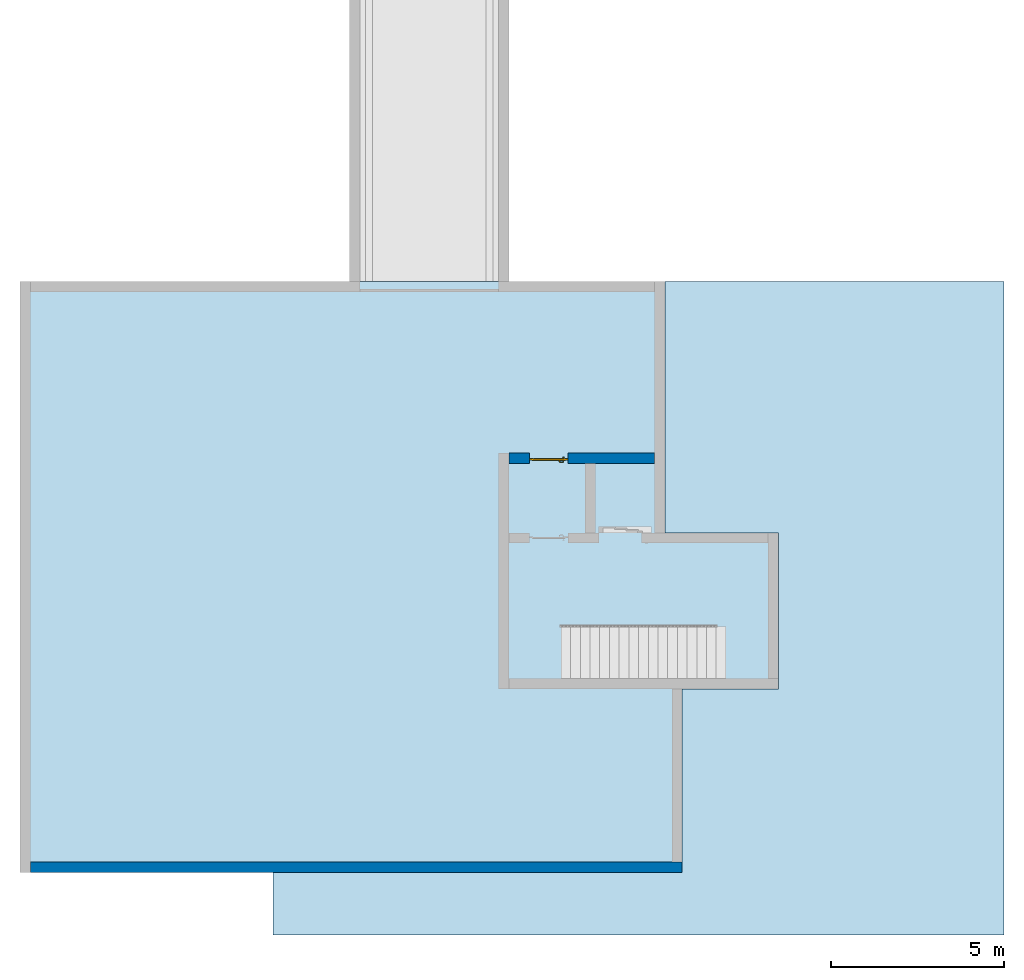
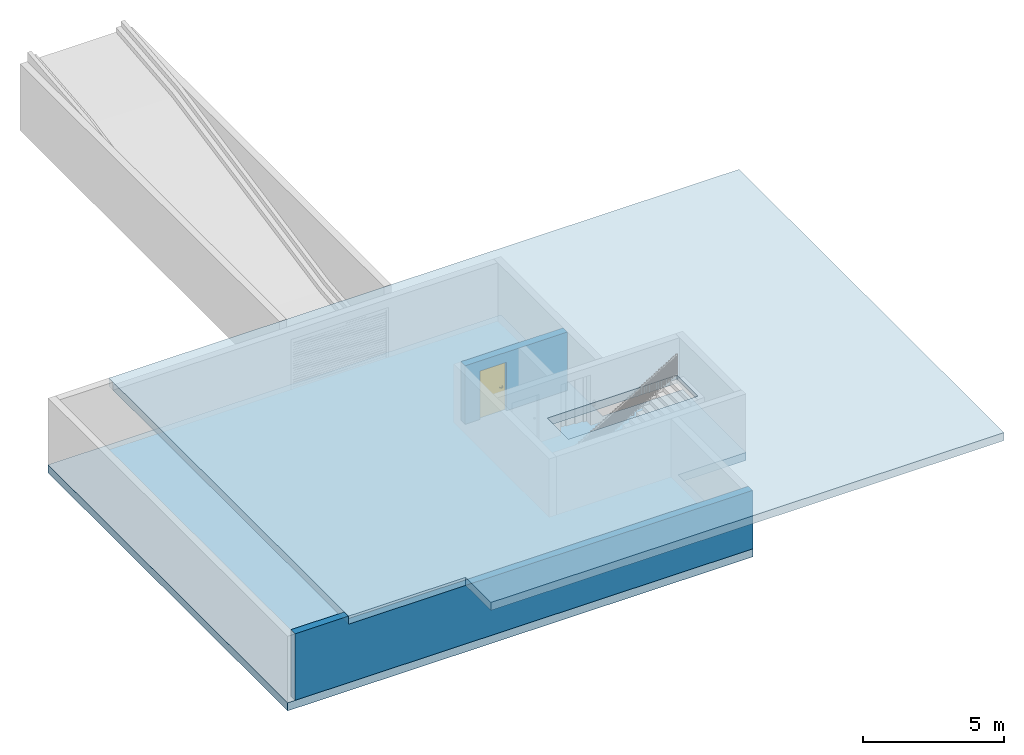
# One storey, part 1 of 6: 2 slabs, 2 walls, 1 door, 1 opening.
"""IFC4 building model written with IfcOpenShell, lengths in metres."""

from ifc_helpers import new_model, entity, si_unit, converted_unit, derived_unit, direction, frame, origin_with_axes, place, context, subcontext, project, spatial, polygons, source, transform, mapped, material, type_object, element, fill, save


model = new_model("IFC4")

# Units and contexts
model_context = context("Model", 3, precision=1e-05, world=origin_with_axes(), true_north=direction((0.0, 1.0)))
body_context = subcontext(model_context, "Body", "Model", "MODEL_VIEW")
ifc_project = project(units=[si_unit("LENGTHUNIT", "METRE"), si_unit("AREAUNIT", "SQUARE_METRE"), si_unit("VOLUMEUNIT", "CUBIC_METRE"), converted_unit("PLANEANGLEUNIT", "DEGREE", entity("IfcPlaneAngleMeasure", 0.0174532925199), si_unit("PLANEANGLEUNIT", "RADIAN"), dimensions=[0, 0, 0, 0, 0, 0, 0]), converted_unit("TIMEUNIT", "Year", entity("IfcTimeMeasure", 31556926.0), si_unit("TIMEUNIT", "SECOND"), dimensions=[0, 0, 1, 0, 0, 0, 0]), si_unit("MASSUNIT", "GRAM", prefix="KILO"), si_unit("THERMODYNAMICTEMPERATUREUNIT", "DEGREE_CELSIUS"), si_unit("LUMINOUSINTENSITYUNIT", "LUMEN"), si_unit("ENERGYUNIT", "JOULE", prefix="MEGA"), derived_unit("THERMALCONDUCTANCEUNIT", [(si_unit("POWERUNIT", "WATT"), 1), (si_unit("LENGTHUNIT", "METRE"), -1), (si_unit("THERMODYNAMICTEMPERATUREUNIT", "KELVIN"), -1)]), derived_unit("SPECIFICHEATCAPACITYUNIT", [(si_unit("ENERGYUNIT", "JOULE"), 1), (si_unit("MASSUNIT", "GRAM", prefix="KILO"), -1), (si_unit("THERMODYNAMICTEMPERATUREUNIT", "KELVIN"), -1)]), derived_unit("MASSDENSITYUNIT", [(si_unit("MASSUNIT", "GRAM", prefix="KILO"), 1), (si_unit("VOLUMEUNIT", "CUBIC_METRE"), -1)])], contexts=[model_context])

# Site, building, storey, space
site_placement = place(None, origin_with_axes())
site = spatial("IfcSite", under=ifc_project, at=site_placement, CompositionType="ELEMENT")
building_placement = place(site_placement, origin_with_axes())
building = spatial("IfcBuilding", under=site, at=building_placement, CompositionType="ELEMENT")
storey_placement = place(building_placement, frame((0.0, 0.0, -2.89), z_axis=(0.0, 0.0, 1.0), x_axis=(1.0, 0.0, 0.0)))
storey = spatial("IfcBuildingStorey", under=building, at=storey_placement, Name="-1. Geschoss", CompositionType="ELEMENT", Elevation=-2.89)
space_placement = place(storey_placement, frame((-13.7421993804, 7.17118776896, 0.0), z_axis=(0.0, 0.0, 1.0), x_axis=(-1.0, 0.0, 0.0)))
space = spatial("IfcSpace", under=storey, at=space_placement, CompositionType="ELEMENT", PredefinedType="INTERNAL")

# Slabs
ifc_material = material()
slab_type = type_object("IfcSlabType", Name="350", PredefinedType="NOTDEFINED")
slab_1_placement = place(space_placement, frame((-2.0, -1.75, 2.89), z_axis=(0.0, 0.0, 1.0), x_axis=(-1.0, 0.0, 0.0)))
element("IfcSlab", 1, at=slab_1_placement, inside=space, type_object=slab_type, material=ifc_material, Name="Decke-001", PredefinedType="NOTDEFINED", context=body_context, shape_type="Tessellation", body=[
    polygons([(-4.8, -17.05, 0.0), (-4.8, 0.0, 0.0), (-4.8, 0.0, -0.35), (-4.8, -17.05, -0.35), (21.08, -18.85, 0.0), (21.08, 0.0, 0.0), (0.0, -17.05, 0.0), (0.0, -18.85, 0.0), (12.78, -11.45, 0.0), (7.46, -11.45, 0.0), (7.46, -9.95, 0.0), (12.78, -9.95, 0.0), (21.08, 0.0, -0.35), (21.08, -18.85, -0.35), (0.0, -18.85, -0.35), (0.0, -17.05, -0.35), (12.78, -11.45, -0.35), (12.78, -9.95, -0.35), (7.46, -9.95, -0.35), (7.46, -11.45, -0.35)], [[[1, 2, 3, 4]], [[5, 6, 2, 1, 7, 8], [9, 10, 11, 12]], [[2, 6, 13, 3]], [[4, 3, 13, 14, 15, 16], [17, 18, 19, 20]], [[7, 1, 4, 16]], [[6, 5, 14, 13]], [[8, 7, 16, 15]], [[5, 8, 15, 14]], [[10, 9, 17, 20]], [[11, 10, 20, 19]], [[12, 11, 19, 18]], [[9, 12, 18, 17]]], closed=True),
])
slab_2_placement = place(storey_placement, frame((-19.0421993804, 8.92118776896, 0.0), z_axis=(0.0, 0.0, 1.0), x_axis=(1.0, 0.0, 0.0)))
element("IfcSlab", 2, at=slab_2_placement, inside=storey, type_object=slab_type, material=ifc_material, Name="Decke-001", PredefinedType="NOTDEFINED", context=body_context, shape_type="Tessellation", body=[
    polygons([(0.0, 0.0, 0.0), (0.0, 0.0, -0.35), (0.0, -17.05, -0.35), (0.0, -17.05, 0.0), (18.6, 0.0, 0.0), (18.6, 0.0, -0.35), (18.6, -7.25, -0.35), (21.88, -7.25, -0.35), (21.88, -11.75, -0.35), (19.1, -11.75, -0.35), (19.1, -17.05, -0.35), (19.1, -17.05, 0.0), (19.1, -11.75, 0.0), (21.88, -11.75, 0.0), (21.88, -7.25, 0.0), (18.6, -7.25, 0.0)], [[[1, 2, 3, 4]], [[5, 6, 2, 1]], [[3, 2, 6, 7, 8, 9, 10, 11]], [[4, 3, 11, 12]], [[5, 1, 4, 12, 13, 14, 15, 16]], [[16, 7, 6, 5]], [[15, 8, 7, 16]], [[14, 9, 8, 15]], [[13, 10, 9, 14]], [[12, 11, 10, 13]]], closed=True),
])

# Wall
wall_type = type_object("IfcWallType", Name="300", PredefinedType="NOTDEFINED")
wall_1_placement = place(storey_placement, frame((-0.0921993803965, -8.12881223104, 0.0), z_axis=(0.0, 0.0, 1.0), x_axis=(-1.0, 0.0, 0.0)))
element("IfcWall", 3, at=wall_1_placement, inside=storey, type_object=wall_type, material=ifc_material, Name="Wand-001", PredefinedType="NOTDEFINED", context=body_context, shape_type="Tessellation", body=[
    polygons([(16.45, -0.3, 2.54), (-0.15, -0.3, 2.54), (-0.15, -0.3, 0.0), (18.65, -0.3, 0.0), (18.65, -0.3, 2.89), (16.45, -0.3, 2.89), (16.45, 0.0, 2.54), (11.65, 0.0, 2.54), (-0.15, 0.0, 2.54), (-0.15, 0.0, 0.0), (18.65, 0.0, 0.0), (18.65, 0.0, 2.89), (16.45, 0.0, 2.89)], [[[1, 2, 3, 4, 5, 6]], [[7, 8, 9, 2, 1]], [[3, 2, 9, 10]], [[10, 11, 4, 3]], [[11, 12, 5, 4]], [[12, 13, 6, 5]], [[7, 1, 6, 13]], [[10, 9, 8, 7, 13, 12, 11]]], closed=True),
])

# Wall, opening, door
wall_2_placement = place(storey_placement, frame((-5.2421993804, 3.67118776896, 0.0), z_axis=(0.0, 0.0, 1.0), x_axis=(1.0, 0.0, 0.0)))
wall_2 = element("IfcWall", 4, at=wall_2_placement, inside=storey, type_object=wall_type, material=ifc_material, Name="Wand-001", PredefinedType="NOTDEFINED", context=body_context, shape_type="Tessellation", body=[
    polygons([(2.0, 0.15, 0.0), (2.0, 0.0, 0.0), (2.0, 0.0, 2.1), (2.0, 0.3, 2.1), (2.0, 0.3, 0.0), (4.5, 0.3, 0.0), (4.5, 0.0, 0.0), (4.5, 0.0, 2.54), (0.3, 0.0, 2.54), (0.3, 0.0, 0.0), (0.9, 0.0, 0.0), (0.9, 0.0, 2.1), (0.9, 0.3, 2.1), (0.9, 0.3, 0.0), (0.3, 0.3, 0.0), (0.3, 0.3, 2.54), (4.5, 0.3, 2.54), (0.9, 0.15, 0.0)], [[[1, 2, 3, 4, 5]], [[2, 1, 5, 6, 7]], [[3, 2, 7, 8, 9, 10, 11, 12]], [[4, 3, 12, 13]], [[6, 5, 4, 13, 14, 15, 16, 17]], [[8, 7, 6, 17]], [[17, 16, 9, 8]], [[16, 15, 10, 9]], [[18, 11, 10, 15, 14]], [[12, 11, 18, 14, 13]]], closed=True),
])
opening_placement = place(wall_2_placement, frame((1.45, 0.0, 0.0), z_axis=(0.0, 0.0, 1.0), x_axis=(1.0, 0.0, 0.0)))
opening = element("IfcOpeningElement", 5, at=opening_placement, cuts=wall_2, context=body_context, identifier="Reference", shape_type="Tessellation", body=[
    polygons([(-0.55, 0.15, 0.0), (-0.55, 0.15, 2.1), (-0.55, 0.301, 2.1), (-0.55, 0.301, 0.0), (-0.55, -0.001, 0.0), (-0.55, -0.000999999999999, 2.1), (0.55, 0.15, 2.1), (0.55, 0.301, 2.1), (0.55, -0.001, 2.1), (0.55, 0.301, 0.0), (0.55, 0.15, 0.0), (0.55, -0.001, 0.0)], [[[1, 2, 3, 4]], [[2, 1, 5, 6]], [[7, 8, 3, 2, 6, 9]], [[8, 10, 4, 3]], [[1, 4, 10, 11, 12, 5]], [[6, 5, 12, 9]], [[7, 11, 10, 8]], [[11, 7, 9, 12]]], closed=True),
])
door_type = type_object("IfcDoorType", Name="Eingang 01 1-Fl 26", OperationType="SINGLE_SWING_RIGHT", PredefinedType="DOOR")
shared_shape = source(origin_with_axes(), body_context, "Body", "Tessellation", [
    polygons([(0.55, -0.05, 0.0), (0.55, -0.03, 0.0), (0.55, -0.03, 2.1), (0.55, -0.05, 2.1), (0.45, -0.05, 0.0), (0.45, -0.03, 0.0), (0.45, -0.03, 2.0), (0.1301, -0.03, 2.0), (0.0001, -0.03, 2.0), (-0.45, -0.03, 2.0), (-0.45, -0.03, 0.0), (-0.55, -0.03, 0.0), (-0.55, -0.03, 2.1), (-0.55, -0.05, 2.1), (-0.55, -0.05, 0.0), (-0.45, -0.05, 0.0), (-0.45, -0.05, 2.0), (0.0001, -0.05, 2.0), (0.1301, -0.05, 2.0), (0.45, -0.05, 2.0)], [[[1, 2, 3, 4]], [[5, 6, 2, 1]], [[2, 6, 7, 8, 9, 10, 11, 12, 13, 3]], [[4, 3, 13, 14]], [[1, 4, 14, 15, 16, 17, 18, 19, 20, 5]], [[20, 7, 6, 5]], [[19, 8, 7, 20]], [[18, 9, 8, 19]], [[17, 10, 9, 18]], [[16, 11, 10, 17]], [[15, 12, 11, 16]], [[14, 13, 12, 15]]], closed=True),
    polygons([(0.55, -0.03, 0.0), (0.55, 0.0, 0.0), (0.55, 0.0, 2.1), (0.55, -0.03, 2.1), (0.48, -0.03, 0.0), (0.48, 0.0, 0.0), (0.48, 0.0, 2.03), (0.1001, 0.0, 2.03), (0.0301, 0.0, 2.03), (-0.48, 0.0, 2.03), (-0.48, 0.0, 0.0), (-0.55, 0.0, 0.0), (-0.55, 0.0, 2.1), (-0.55, -0.03, 2.1), (-0.55, -0.03, 0.0), (-0.48, -0.03, 0.0), (-0.48, -0.03, 2.03), (0.0301, -0.03, 2.03), (0.1001, -0.03, 2.03), (0.48, -0.03, 2.03)], [[[1, 2, 3, 4]], [[5, 6, 2, 1]], [[2, 6, 7, 8, 9, 10, 11, 12, 13, 3]], [[4, 3, 13, 14]], [[1, 4, 14, 15, 16, 17, 18, 19, 20, 5]], [[20, 7, 6, 5]], [[19, 8, 7, 20]], [[18, 9, 8, 19]], [[17, 10, 9, 18]], [[16, 11, 10, 17]], [[15, 12, 11, 16]], [[14, 13, 12, 15]]], closed=True),
    polygons([(0.48, 0.01, 0.0), (-0.48, 0.01, 0.0), (-0.48, 0.01, 2.03), (0.48, 0.01, 2.03), (0.48, -0.03, 0.0), (-0.48, -0.03, 0.0), (-0.48, -0.03, 2.03), (0.48, -0.03, 2.03)], [[[1, 2, 3, 4]], [[2, 1, 5, 6]], [[3, 2, 6, 7]], [[4, 3, 7, 8]], [[1, 4, 8, 5]], [[6, 5, 8, 7]]], closed=True),
    polygons([(0.445, -0.05, 0.0), (0.445, -0.05, 0.05), (-0.445, -0.05, 0.05), (-0.445, -0.05, 0.0), (0.445, -0.03, 0.0), (0.445, -0.03, 0.07), (0.445, -0.035, 0.07), (-0.445, -0.035, 0.07), (-0.445, -0.03, 0.07), (-0.445, -0.03, 0.0)], [[[1, 2, 3, 4]], [[1, 5, 6, 7, 2]], [[2, 7, 8, 3]], [[4, 3, 8, 9, 10]], [[5, 1, 4, 10]], [[6, 5, 10, 9]], [[7, 6, 9, 8]]], closed=True),
    polygons([(-0.4335, 0.02, 1.0733826859), (-0.4335, 0.0199, 1.0733826859), (-0.42, 0.0199, 1.077), (-0.42, 0.02, 1.077), (-0.443382685902, 0.02, 1.0635), (-0.443382685902, 0.0199, 1.0635), (-0.4335, 0.0101, 1.0733826859), (-0.42, 0.0101, 1.077), (-0.4065, 0.0199, 1.0733826859), (-0.4065, 0.02, 1.0733826859), (-0.396617314098, 0.02, 1.0635), (-0.393, 0.02, 1.05), (-0.396617314098, 0.02, 1.0365), (-0.4065, 0.02, 1.0266173141), (-0.42, 0.02, 1.023), (-0.4335, 0.02, 1.0266173141), (-0.443382685902, 0.02, 1.0365), (-0.447, 0.02, 1.05), (-0.447, 0.0199, 1.05), (-0.443382685902, 0.0101, 1.0635), (-0.4335, 0.01, 1.0733826859), (-0.42, 0.01, 1.077), (-0.4065, 0.0101, 1.0733826859), (-0.396617314098, 0.0199, 1.0635), (-0.393, 0.0199, 1.05), (-0.396617314098, 0.0199, 1.0365), (-0.4065, 0.0199, 1.0266173141), (-0.42, 0.0199, 1.023), (-0.4335, 0.0199, 1.0266173141), (-0.443382685902, 0.0199, 1.0365), (-0.447, 0.0101, 1.05), (-0.443382685902, 0.01, 1.0635), (-0.447, 0.01, 1.05), (-0.443382685902, 0.01, 1.0365), (-0.4335, 0.01, 1.0266173141), (-0.42, 0.01, 1.023), (-0.4065, 0.01, 1.0266173141), (-0.396617314098, 0.01, 1.0365), (-0.393, 0.01, 1.05), (-0.396617314098, 0.01, 1.0635), (-0.4065, 0.01, 1.0733826859), (-0.396617314098, 0.0101, 1.0635), (-0.393, 0.0101, 1.05), (-0.396617314098, 0.0101, 1.0365), (-0.4065, 0.0101, 1.0266173141), (-0.42, 0.0101, 1.023), (-0.4335, 0.0101, 1.0266173141), (-0.443382685902, 0.0101, 1.0365)], [[[1, 2, 3, 4]], [[5, 6, 2, 1]], [[2, 7, 8, 3]], [[4, 3, 9, 10]], [[4, 10, 11, 12, 13, 14, 15, 16, 17, 18, 5, 1]], [[18, 19, 6, 5]], [[6, 20, 7, 2]], [[7, 21, 22, 8]], [[3, 8, 23, 9]], [[10, 9, 24, 11]], [[11, 24, 25, 12]], [[12, 25, 26, 13]], [[13, 26, 27, 14]], [[14, 27, 28, 15]], [[15, 28, 29, 16]], [[16, 29, 30, 17]], [[17, 30, 19, 18]], [[19, 31, 20, 6]], [[20, 32, 21, 7]], [[22, 21, 32, 33, 34, 35, 36, 37, 38, 39, 40, 41]], [[8, 22, 41, 23]], [[9, 23, 42, 24]], [[24, 42, 43, 25]], [[25, 43, 44, 26]], [[26, 44, 45, 27]], [[27, 45, 46, 28]], [[28, 46, 47, 29]], [[29, 47, 48, 30]], [[30, 48, 31, 19]], [[31, 33, 32, 20]], [[48, 34, 33, 31]], [[47, 35, 34, 48]], [[46, 36, 35, 47]], [[45, 37, 36, 46]], [[44, 38, 37, 45]], [[43, 39, 38, 44]], [[42, 40, 39, 43]], [[23, 41, 40, 42]]], closed=True),
    polygons([(-0.412532169224, 0.019, 0.959692280177), (-0.415, 0.019, 0.9544), (-0.415, 0.019, 0.952886751346), (-0.397569942042, 0.019, 0.96295), (-0.40705, 0.019, 0.972430057958), (-0.413279754556, 0.019, 0.961639806549), (-0.412532169224, 0.02, 0.959692280177), (-0.415, 0.02, 0.9544), (-0.415, 0.02, 0.952886751346), (-0.415, 0.02, 0.95), (-0.415, 0.02, 0.947113248654), (-0.415, 0.02, 0.941339745962), (-0.415, 0.02, 0.9375), (-0.415, 0.019, 0.9375), (-0.415, 0.019, 0.941339745962), (-0.415, 0.019, 0.947113248654), (-0.415, 0.019, 0.95), (-0.3941, 0.019, 0.95), (-0.397483339502, 0.019, 0.963), (-0.407, 0.019, 0.972516660498), (-0.414624817685, 0.019, 0.965143815798), (-0.42, 0.019, 0.9759), (-0.42, 0.019, 0.967425445323), (-0.414624817685, 0.02, 0.965143815798), (-0.413279754556, 0.02, 0.961639806549), (-0.40655, 0.02, 0.973296083362), (-0.396703916638, 0.02, 0.96345), (-0.3931, 0.02, 0.95), (-0.396703916638, 0.02, 0.93655), (-0.40655, 0.02, 0.926703916638), (-0.42, 0.02, 0.9231), (-0.42, 0.02, 0.9325), (-0.416464466094, 0.02, 0.933964466094), (-0.416464466094, 0.019, 0.933964466094), (-0.40705, 0.019, 0.927569942042), (-0.42, 0.019, 0.9325), (-0.42, 0.019, 0.9241), (-0.397569942042, 0.019, 0.93705), (-0.394, 0.019, 0.95), (-0.397483339502, 0.0189, 0.963), (-0.407, 0.0189, 0.972516660498), (-0.42, 0.019, 0.976), (-0.425375182315, 0.019, 0.965143815798), (-0.43295, 0.019, 0.972430057958), (-0.426720245444, 0.019, 0.961639806549), (-0.42, 0.02, 0.967425445323), (-0.42, 0.02, 0.9769), (-0.396617314098, 0.02, 0.9635), (-0.4065, 0.02, 0.973382685902), (-0.393, 0.02, 0.95), (-0.396617314098, 0.02, 0.9365), (-0.4065, 0.02, 0.926617314098), (-0.43345, 0.02, 0.926703916638), (-0.425, 0.02, 0.941339745962), (-0.425, 0.02, 0.9375), (-0.423535533906, 0.02, 0.933964466094), (-0.42, 0.02, 0.923), (-0.423535533906, 0.019, 0.933964466094), (-0.425, 0.019, 0.9375), (-0.425, 0.019, 0.941339745962), (-0.43295, 0.019, 0.927569942042), (-0.42, 0.019, 0.924), (-0.407, 0.019, 0.927483339502), (-0.397483339502, 0.019, 0.937), (-0.394, 0.0189, 0.95), (-0.397483339502, 0.0101, 0.963), (-0.407, 0.0101, 0.972516660498), (-0.42, 0.0189, 0.976), (-0.433, 0.019, 0.972516660498), (-0.425375182315, 0.02, 0.965143815798), (-0.427467830776, 0.019, 0.959692280177), (-0.442430057958, 0.019, 0.96295), (-0.425, 0.019, 0.952886751346), (-0.425, 0.019, 0.9544), (-0.427467830776, 0.02, 0.959692280177), (-0.426720245444, 0.02, 0.961639806549), (-0.43345, 0.02, 0.973296083362), (-0.42, 0.02, 0.977), (-0.396617314098, 0.0199, 0.9635), (-0.4065, 0.0199, 0.973382685902), (-0.393, 0.0199, 0.95), (-0.396617314098, 0.0199, 0.9365), (-0.4065, 0.0199, 0.926617314098), (-0.443296083362, 0.02, 0.93655), (-0.425, 0.02, 0.947113248654), (-0.425, 0.02, 0.9544), (-0.425, 0.019, 0.95), (-0.425, 0.019, 0.947113248654), (-0.425, 0.02, 0.95), (-0.425, 0.02, 0.952886751346), (-0.4335, 0.02, 0.926617314098), (-0.42, 0.0199, 0.923), (-0.442430057958, 0.019, 0.93705), (-0.433, 0.019, 0.927483339502), (-0.42, 0.0189, 0.924), (-0.407, 0.0189, 0.927483339502), (-0.397483339502, 0.0189, 0.937), (-0.394, 0.0101, 0.95), (-0.397483339502, 0.01, 0.963), (-0.407, 0.01, 0.972516660498), (-0.42, 0.0101, 0.976), (-0.433, 0.0189, 0.972516660498), (-0.442516660498, 0.019, 0.963), (-0.4459, 0.019, 0.95), (-0.443296083362, 0.02, 0.96345), (-0.4335, 0.02, 0.973382685902), (-0.42, 0.0199, 0.977), (-0.396617314098, 0.0101, 0.9635), (-0.4065, 0.0101, 0.973382685902), (-0.393, 0.0101, 0.95), (-0.396617314098, 0.0101, 0.9365), (-0.4065, 0.0101, 0.926617314098), (-0.443382685902, 0.02, 0.9365), (-0.4469, 0.02, 0.95), (-0.4335, 0.0199, 0.926617314098), (-0.42, 0.0101, 0.923), (-0.442516660498, 0.019, 0.937), (-0.433, 0.0189, 0.927483339502), (-0.42, 0.0101, 0.924), (-0.407, 0.0101, 0.927483339502), (-0.397483339502, 0.0101, 0.937), (-0.394, 0.01, 0.95), (-0.397396736961, 0.01, 0.96305), (-0.40695, 0.01, 0.972603263039), (-0.42, 0.01, 0.976), (-0.433, 0.0101, 0.972516660498), (-0.442516660498, 0.0189, 0.963), (-0.446, 0.019, 0.95), (-0.443382685902, 0.02, 0.9635), (-0.4335, 0.0199, 0.973382685902), (-0.42, 0.0101, 0.977), (-0.396617314098, 0.01, 0.9635), (-0.4065, 0.01, 0.973382685902), (-0.393, 0.01, 0.95), (-0.396617314098, 0.01, 0.9365), (-0.4065, 0.01, 0.926617314098), (-0.447, 0.02, 0.95), (-0.443382685902, 0.0199, 0.9365), (-0.4335, 0.0101, 0.926617314098), (-0.42, 0.01, 0.923), (-0.442516660498, 0.0189, 0.937), (-0.433, 0.0101, 0.927483339502), (-0.42, 0.01, 0.924), (-0.407, 0.01, 0.927483339502), (-0.397483339502, 0.01, 0.937), (-0.3939, 0.01, 0.95), (-0.396703916638, 0.01, 0.96345), (-0.40655, 0.01, 0.973296083362), (-0.42, 0.01, 0.9761), (-0.433, 0.01, 0.972516660498), (-0.442516660498, 0.0101, 0.963), (-0.446, 0.0189, 0.95), (-0.443382685902, 0.0199, 0.9635), (-0.4335, 0.0101, 0.973382685902), (-0.42, 0.01, 0.977), (-0.3931, 0.01, 0.95), (-0.396703916638, 0.01, 0.93655), (-0.40655, 0.01, 0.926703916638), (-0.447, 0.0199, 0.95), (-0.443382685902, 0.0101, 0.9365), (-0.4335, 0.01, 0.926617314098), (-0.42, 0.01, 0.9231), (-0.442516660498, 0.0101, 0.937), (-0.433, 0.01, 0.927483339502), (-0.42, 0.01, 0.9239), (-0.40695, 0.01, 0.927396736961), (-0.397396736961, 0.01, 0.93695), (-0.42, 0.01, 0.9769), (-0.43305, 0.01, 0.972603263039), (-0.442516660498, 0.01, 0.963), (-0.446, 0.0101, 0.95), (-0.443382685902, 0.0101, 0.9635), (-0.4335, 0.01, 0.973382685902), (-0.447, 0.0101, 0.95), (-0.443382685902, 0.01, 0.9365), (-0.43345, 0.01, 0.926703916638), (-0.442516660498, 0.01, 0.937), (-0.43305, 0.01, 0.927396736961), (-0.43345, 0.01, 0.973296083362), (-0.442603263039, 0.01, 0.96305), (-0.446, 0.01, 0.95), (-0.443382685902, 0.01, 0.9635), (-0.447, 0.01, 0.95), (-0.443296083362, 0.01, 0.93655), (-0.442603263039, 0.01, 0.93695), (-0.443296083362, 0.01, 0.96345), (-0.4461, 0.01, 0.95), (-0.4469, 0.01, 0.95)], [[[1, 2, 3, 4, 5, 6]], [[2, 1, 7, 8]], [[2, 8, 9, 10, 11, 12, 13, 14, 15, 16, 17, 3]], [[17, 18, 4, 3]], [[4, 19, 20, 5]], [[21, 6, 5, 22, 23]], [[1, 6, 21, 24, 25, 7]], [[7, 25, 26, 27, 9, 8]], [[9, 27, 28, 10]], [[10, 28, 29, 11]], [[11, 29, 30, 12]], [[31, 32, 33, 13, 12, 30]], [[14, 13, 33, 34]], [[35, 15, 14, 34, 36, 37]], [[15, 35, 38, 16]], [[16, 38, 18, 17]], [[18, 39, 19, 4]], [[19, 40, 41, 20]], [[5, 20, 42, 22]], [[43, 23, 22, 44, 45]], [[21, 23, 46, 24]], [[24, 46, 47, 26, 25]], [[48, 27, 26, 49]], [[50, 28, 27, 48]], [[51, 29, 28, 50]], [[52, 30, 29, 51]], [[53, 54, 55, 56, 32, 31]], [[34, 33, 32, 36]], [[57, 31, 30, 52]], [[37, 36, 58, 59, 60, 61]], [[37, 62, 63, 35]], [[35, 63, 64, 38]], [[38, 64, 39, 18]], [[39, 65, 40, 19]], [[40, 66, 67, 41]], [[20, 41, 68, 42]], [[22, 42, 69, 44]], [[23, 43, 70, 46]], [[71, 45, 44, 72, 73, 74]], [[43, 45, 71, 75, 76, 70]], [[70, 76, 77, 47, 46]], [[49, 26, 47, 78]], [[79, 48, 49, 80]], [[81, 50, 48, 79]], [[82, 51, 50, 81]], [[83, 52, 51, 82]], [[54, 53, 84, 85]], [[86, 74, 73, 87, 88, 60, 59, 55, 54, 85, 89, 90]], [[58, 56, 55, 59]], [[36, 32, 56, 58]], [[91, 53, 31, 57]], [[92, 57, 52, 83]], [[88, 93, 61, 60]], [[61, 94, 62, 37]], [[62, 95, 96, 63]], [[63, 96, 97, 64]], [[64, 97, 65, 39]], [[65, 98, 66, 40]], [[66, 99, 100, 67]], [[41, 67, 101, 68]], [[42, 68, 102, 69]], [[44, 69, 103, 72]], [[73, 72, 104, 87]], [[71, 74, 86, 75]], [[75, 86, 90, 105, 77, 76]], [[78, 47, 77, 106]], [[80, 49, 78, 107]], [[108, 79, 80, 109]], [[110, 81, 79, 108]], [[111, 82, 81, 110]], [[112, 83, 82, 111]], [[113, 84, 53, 91]], [[85, 84, 114, 89]], [[87, 104, 93, 88]], [[89, 114, 105, 90]], [[115, 91, 57, 92]], [[116, 92, 83, 112]], [[93, 117, 94, 61]], [[94, 118, 95, 62]], [[95, 119, 120, 96]], [[96, 120, 121, 97]], [[97, 121, 98, 65]], [[98, 122, 99, 66]], [[99, 123, 124, 100]], [[67, 100, 125, 101]], [[68, 101, 126, 102]], [[69, 102, 127, 103]], [[72, 103, 128, 104]], [[106, 77, 105, 129]], [[107, 78, 106, 130]], [[109, 80, 107, 131]], [[132, 108, 109, 133]], [[134, 110, 108, 132]], [[135, 111, 110, 134]], [[136, 112, 111, 135]], [[137, 114, 84, 113]], [[138, 113, 91, 115]], [[104, 128, 117, 93]], [[129, 105, 114, 137]], [[139, 115, 92, 116]], [[140, 116, 112, 136]], [[117, 141, 118, 94]], [[118, 142, 119, 95]], [[119, 143, 144, 120]], [[120, 144, 145, 121]], [[121, 145, 122, 98]], [[122, 146, 123, 99]], [[123, 147, 148, 124]], [[100, 124, 149, 125]], [[101, 125, 150, 126]], [[102, 126, 151, 127]], [[103, 127, 152, 128]], [[130, 106, 129, 153]], [[131, 107, 130, 154]], [[133, 109, 131, 155]], [[147, 132, 133, 148]], [[156, 134, 132, 147]], [[157, 135, 134, 156]], [[158, 136, 135, 157]], [[159, 137, 113, 138]], [[160, 138, 115, 139]], [[128, 152, 141, 117]], [[153, 129, 137, 159]], [[161, 139, 116, 140]], [[162, 140, 136, 158]], [[141, 163, 142, 118]], [[142, 164, 143, 119]], [[143, 165, 166, 144]], [[144, 166, 167, 145]], [[145, 167, 146, 122]], [[146, 156, 147, 123]], [[124, 148, 168, 149]], [[125, 149, 169, 150]], [[126, 150, 170, 151]], [[127, 151, 171, 152]], [[154, 130, 153, 172]], [[155, 131, 154, 173]], [[148, 133, 155, 168]], [[167, 157, 156, 146]], [[166, 158, 157, 167]], [[174, 159, 138, 160]], [[175, 160, 139, 161]], [[152, 171, 163, 141]], [[172, 153, 159, 174]], [[176, 161, 140, 162]], [[165, 162, 158, 166]], [[163, 177, 164, 142]], [[164, 178, 165, 143]], [[149, 168, 179, 169]], [[150, 169, 180, 170]], [[151, 170, 181, 171]], [[173, 154, 172, 182]], [[168, 155, 173, 179]], [[183, 174, 160, 175]], [[184, 175, 161, 176]], [[171, 181, 177, 163]], [[182, 172, 174, 183]], [[178, 176, 162, 165]], [[177, 185, 178, 164]], [[169, 179, 186, 180]], [[170, 180, 187, 181]], [[179, 173, 182, 186]], [[188, 183, 175, 184]], [[185, 184, 176, 178]], [[181, 187, 185, 177]], [[186, 182, 183, 188]], [[180, 186, 188, 187]], [[187, 188, 184, 185]]], closed=True),
    polygons([(-0.43, 0.02, 1.05), (-0.43, 0.0509849140336, 1.05), (-0.427071067812, 0.050696439392, 1.04292893219), (-0.427071067812, 0.02, 1.04292893219), (-0.427071067812, 0.02, 1.05707106781), (-0.427071067812, 0.050696439392, 1.05707106781), (-0.428277987014, 0.0596420579258, 1.05), (-0.425518993221, 0.0584992452783, 1.04292893219), (-0.42, 0.05, 1.04), (-0.42, 0.02, 1.04), (-0.42, 0.02, 1.06), (-0.42, 0.05, 1.06), (-0.425518993221, 0.0584992452783, 1.05707106781), (-0.422816199938, 0.0678161999379, 1.05), (-0.420704557509, 0.0657045575088, 1.04292893219), (-0.418858192988, 0.0557402514855, 1.04), (-0.412928932188, 0.049303560608, 1.04292893219), (-0.412928932188, 0.02, 1.04292893219), (-0.412928932188, 0.02, 1.05707106781), (-0.412928932188, 0.049303560608, 1.05707106781), (-0.418858192988, 0.0557402514855, 1.06), (-0.420704557509, 0.0657045575088, 1.05707106781), (-0.414642057926, 0.0732779870137, 1.05), (-0.413499245278, 0.0705189932208, 1.04292893219), (-0.415606601718, 0.0606066017178, 1.04), (-0.412197392755, 0.0529812576926, 1.04292893219), (-0.41, 0.0490150859664, 1.05), (-0.41, 0.02, 1.05), (-0.412197392755, 0.0529812576926, 1.05707106781), (-0.415606601718, 0.0606066017178, 1.06), (-0.413499245278, 0.0705189932208, 1.05707106781), (-0.405984914034, 0.075, 1.05), (-0.405696439392, 0.0720710678119, 1.04292893219), (-0.410740251485, 0.0638581929877, 1.04), (-0.410508645927, 0.0555086459268, 1.04292893219), (-0.409438398962, 0.0518384450452, 1.05), (-0.410508645927, 0.0555086459268, 1.05707106781), (-0.410740251485, 0.0638581929877, 1.06), (-0.405696439392, 0.0720710678119, 1.05707106781), (-0.324015085966, 0.075, 1.05), (-0.324303560608, 0.0720710678119, 1.04292893219), (-0.405, 0.065, 1.04), (-0.407981257693, 0.0571973927545, 1.04292893219), (-0.408397003498, 0.0533970034977, 1.05), (-0.407981257693, 0.0571973927545, 1.05707106781), (-0.405, 0.065, 1.06), (-0.324303560608, 0.0720710678119, 1.05707106781), (-0.315357942074, 0.0732779870137, 1.05), (-0.316500754722, 0.0705189932208, 1.04292893219), (-0.325, 0.065, 1.04), (-0.404303560608, 0.0579289321881, 1.04292893219), (-0.406838445045, 0.0544383989617, 1.05), (-0.404303560608, 0.0579289321881, 1.05707106781), (-0.325, 0.065, 1.06), (-0.316500754722, 0.0705189932208, 1.05707106781), (-0.307183800062, 0.0678161999379, 1.05), (-0.309295442491, 0.0657045575088, 1.04292893219), (-0.319259748515, 0.0638581929877, 1.04), (-0.325696439392, 0.0579289321881, 1.04292893219), (-0.404015085966, 0.055, 1.05), (-0.325696439392, 0.0579289321881, 1.05707106781), (-0.319259748515, 0.0638581929877, 1.06), (-0.309295442491, 0.0657045575088, 1.05707106781), (-0.301722012986, 0.0596420579258, 1.05), (-0.304481006779, 0.0584992452783, 1.04292893219), (-0.314393398282, 0.0606066017178, 1.04), (-0.322018742307, 0.0571973927545, 1.04292893219), (-0.325984914034, 0.055, 1.05), (-0.322018742307, 0.0571973927545, 1.05707106781), (-0.314393398282, 0.0606066017178, 1.06), (-0.304481006779, 0.0584992452783, 1.05707106781), (-0.3, 0.0509849140336, 1.05), (-0.302928932188, 0.050696439392, 1.04292893219), (-0.311141807012, 0.0557402514855, 1.04), (-0.319491354073, 0.0555086459268, 1.04292893219), (-0.323161554955, 0.0544383989617, 1.05), (-0.319491354073, 0.0555086459268, 1.05707106781), (-0.311141807012, 0.0557402514855, 1.06), (-0.302928932188, 0.050696439392, 1.05707106781), (-0.3, 0.02, 1.05), (-0.302928932188, 0.02, 1.04292893219), (-0.31, 0.05, 1.04), (-0.317802607245, 0.0529812576926, 1.04292893219), (-0.321602996502, 0.0533970034977, 1.05), (-0.317802607245, 0.0529812576926, 1.05707106781), (-0.31, 0.05, 1.06), (-0.302928932188, 0.02, 1.05707106781), (-0.31, 0.02, 1.06), (-0.317071067812, 0.02, 1.05707106781), (-0.32, 0.02, 1.05), (-0.317071067812, 0.02, 1.04292893219), (-0.31, 0.02, 1.04), (-0.317071067812, 0.049303560608, 1.04292893219), (-0.320561601038, 0.0518384450452, 1.05), (-0.317071067812, 0.049303560608, 1.05707106781), (-0.32, 0.0490150859664, 1.05)], [[[1, 2, 3, 4]], [[5, 6, 2, 1]], [[2, 7, 8, 3]], [[4, 3, 9, 10]], [[11, 12, 6, 5]], [[6, 13, 7, 2]], [[7, 14, 15, 8]], [[3, 8, 16, 9]], [[10, 9, 17, 18]], [[19, 20, 12, 11]], [[12, 21, 13, 6]], [[13, 22, 14, 7]], [[14, 23, 24, 15]], [[8, 15, 25, 16]], [[9, 16, 26, 17]], [[18, 17, 27, 28]], [[28, 27, 20, 19]], [[20, 29, 21, 12]], [[21, 30, 22, 13]], [[22, 31, 23, 14]], [[23, 32, 33, 24]], [[15, 24, 34, 25]], [[16, 25, 35, 26]], [[17, 26, 36, 27]], [[27, 36, 29, 20]], [[29, 37, 30, 21]], [[30, 38, 31, 22]], [[31, 39, 32, 23]], [[32, 40, 41, 33]], [[24, 33, 42, 34]], [[25, 34, 43, 35]], [[26, 35, 44, 36]], [[36, 44, 37, 29]], [[37, 45, 38, 30]], [[38, 46, 39, 31]], [[39, 47, 40, 32]], [[40, 48, 49, 41]], [[33, 41, 50, 42]], [[34, 42, 51, 43]], [[35, 43, 52, 44]], [[44, 52, 45, 37]], [[45, 53, 46, 38]], [[46, 54, 47, 39]], [[47, 55, 48, 40]], [[48, 56, 57, 49]], [[41, 49, 58, 50]], [[42, 50, 59, 51]], [[43, 51, 60, 52]], [[52, 60, 53, 45]], [[53, 61, 54, 46]], [[54, 62, 55, 47]], [[55, 63, 56, 48]], [[56, 64, 65, 57]], [[49, 57, 66, 58]], [[50, 58, 67, 59]], [[51, 59, 68, 60]], [[60, 68, 61, 53]], [[61, 69, 62, 54]], [[62, 70, 63, 55]], [[63, 71, 64, 56]], [[64, 72, 73, 65]], [[57, 65, 74, 66]], [[58, 66, 75, 67]], [[59, 67, 76, 68]], [[68, 76, 69, 61]], [[69, 77, 70, 62]], [[70, 78, 71, 63]], [[71, 79, 72, 64]], [[72, 80, 81, 73]], [[65, 73, 82, 74]], [[66, 74, 83, 75]], [[67, 75, 84, 76]], [[76, 84, 77, 69]], [[77, 85, 78, 70]], [[78, 86, 79, 71]], [[79, 87, 80, 72]], [[80, 87, 88, 89, 90, 91, 92, 81]], [[73, 81, 92, 82]], [[74, 82, 93, 83]], [[75, 83, 94, 84]], [[84, 94, 85, 77]], [[85, 95, 86, 78]], [[86, 88, 87, 79]], [[95, 89, 88, 86]], [[96, 90, 89, 95]], [[93, 91, 90, 96]], [[82, 92, 91, 93]], [[83, 93, 96, 94]], [[94, 96, 95, 85]]], closed=False),
    polygons([(-0.414696699141, -0.035, 1.04469669914), (-0.42, -0.035, 1.0425), (-0.425303300859, -0.035, 1.04469669914), (-0.4275, -0.035, 1.05), (-0.425303300859, -0.035, 1.05530330086), (-0.42, -0.035, 1.0575), (-0.414696699141, -0.035, 1.05530330086), (-0.4125, -0.035, 1.05), (-0.414696699141, -0.075, 1.04469669914), (-0.42, -0.075, 1.0425), (-0.425303300859, -0.075, 1.04469669914), (-0.4275, -0.075, 1.05), (-0.425303300859, -0.075, 1.05530330086), (-0.42, -0.075, 1.0575), (-0.414696699141, -0.075, 1.05530330086), (-0.4125, -0.075, 1.05)], [[[1, 2, 3, 4, 5, 6, 7, 8]], [[2, 1, 9, 10]], [[3, 2, 10, 11]], [[4, 3, 11, 12]], [[5, 4, 12, 13]], [[6, 5, 13, 14]], [[7, 6, 14, 15]], [[8, 7, 15, 16]], [[1, 8, 16, 9]], [[9, 16, 15, 14, 13, 12, 11, 10]]], closed=True),
    polygons([(-0.445, -0.03, 0.975), (-0.443096988313, -0.03, 0.965432914191), (-0.443096988313, -0.035, 0.965432914191), (-0.445, -0.035, 0.975), (-0.445, -0.03, 1.1), (-0.443096988313, -0.03, 1.10956708581), (-0.43767766953, -0.03, 1.11767766953), (-0.429567085809, -0.03, 1.12309698831), (-0.42, -0.03, 1.125), (-0.410432914191, -0.03, 1.12309698831), (-0.40232233047, -0.03, 1.11767766953), (-0.396903011687, -0.03, 1.10956708581), (-0.395, -0.03, 1.1), (-0.395, -0.03, 0.975), (-0.396903011687, -0.03, 0.965432914191), (-0.40232233047, -0.03, 0.95732233047), (-0.410432914191, -0.03, 0.951903011687), (-0.42, -0.03, 0.95), (-0.429567085809, -0.03, 0.951903011687), (-0.43767766953, -0.03, 0.95732233047), (-0.43767766953, -0.035, 0.95732233047), (-0.429567085809, -0.035, 0.951903011687), (-0.42, -0.035, 0.95), (-0.410432914191, -0.035, 0.951903011687), (-0.40232233047, -0.035, 0.95732233047), (-0.396903011687, -0.035, 0.965432914191), (-0.395, -0.035, 0.975), (-0.395, -0.035, 1.1), (-0.396903011687, -0.035, 1.10956708581), (-0.40232233047, -0.035, 1.11767766953), (-0.410432914191, -0.035, 1.12309698831), (-0.42, -0.035, 1.125), (-0.429567085809, -0.035, 1.12309698831), (-0.43767766953, -0.035, 1.11767766953), (-0.443096988313, -0.035, 1.10956708581), (-0.445, -0.035, 1.1)], [[[1, 2, 3, 4]], [[1, 5, 6, 7, 8, 9, 10, 11, 12, 13, 14, 15, 16, 17, 18, 19, 20, 2]], [[2, 20, 21, 3]], [[4, 3, 21, 22, 23, 24, 25, 26, 27, 28, 29, 30, 31, 32, 33, 34, 35, 36]], [[5, 1, 4, 36]], [[6, 5, 36, 35]], [[7, 6, 35, 34]], [[8, 7, 34, 33]], [[9, 8, 33, 32]], [[10, 9, 32, 31]], [[11, 10, 31, 30]], [[12, 11, 30, 29]], [[13, 12, 29, 28]], [[14, 13, 28, 27]], [[15, 14, 27, 26]], [[16, 15, 26, 25]], [[17, 16, 25, 24]], [[18, 17, 24, 23]], [[19, 18, 23, 22]], [[20, 19, 22, 21]]], closed=True),
    polygons([(-0.44, -0.075, 1.08), (-0.445, -0.075, 1.07866025404), (-0.445, -0.09, 1.07866025404), (-0.44, -0.09, 1.08), (-0.4, -0.075, 1.08), (-0.395, -0.075, 1.07866025404), (-0.391339745962, -0.075, 1.075), (-0.39, -0.075, 1.07), (-0.39, -0.075, 1.03), (-0.391339745962, -0.075, 1.025), (-0.395, -0.075, 1.02133974596), (-0.4, -0.075, 1.02), (-0.44, -0.075, 1.02), (-0.445, -0.075, 1.02133974596), (-0.448660254038, -0.075, 1.025), (-0.45, -0.075, 1.03), (-0.45, -0.075, 1.07), (-0.448660254038, -0.075, 1.075), (-0.448660254038, -0.09, 1.075), (-0.45, -0.09, 1.07), (-0.45, -0.09, 1.03), (-0.448660254038, -0.09, 1.025), (-0.445, -0.09, 1.02133974596), (-0.44, -0.09, 1.02), (-0.4, -0.09, 1.02), (-0.395, -0.09, 1.02133974596), (-0.391339745962, -0.09, 1.025), (-0.39, -0.09, 1.03), (-0.39, -0.09, 1.07), (-0.391339745962, -0.09, 1.075), (-0.395, -0.09, 1.07866025404), (-0.4, -0.09, 1.08)], [[[1, 2, 3, 4]], [[1, 5, 6, 7, 8, 9, 10, 11, 12, 13, 14, 15, 16, 17, 18, 2]], [[2, 18, 19, 3]], [[4, 3, 19, 20, 21, 22, 23, 24, 25, 26, 27, 28, 29, 30, 31, 32]], [[5, 1, 4, 32]], [[6, 5, 32, 31]], [[7, 6, 31, 30]], [[8, 7, 30, 29]], [[9, 8, 29, 28]], [[10, 9, 28, 27]], [[11, 10, 27, 26]], [[12, 11, 26, 25]], [[13, 12, 25, 24]], [[14, 13, 24, 23]], [[15, 14, 23, 22]], [[16, 15, 22, 21]], [[17, 16, 21, 20]], [[18, 17, 20, 19]]], closed=True),
])
door_placement = place(opening_placement, frame((0.45, 0.0, 0.0), z_axis=(0.0, 0.0, 1.0), x_axis=(-1.0, 0.0, 0.0)))
door = element("IfcDoor", 6, at=door_placement, inside=storey, type_object=door_type, OverallHeight=2.1, OverallWidth=1.1, PredefinedType="DOOR", context=body_context, shape_type="MappedRepresentation", body=[
    mapped(shared_shape, transform((0.45, -0.1, 0.0))),
])
fill(opening, door)

save(model, "model.ifc")
